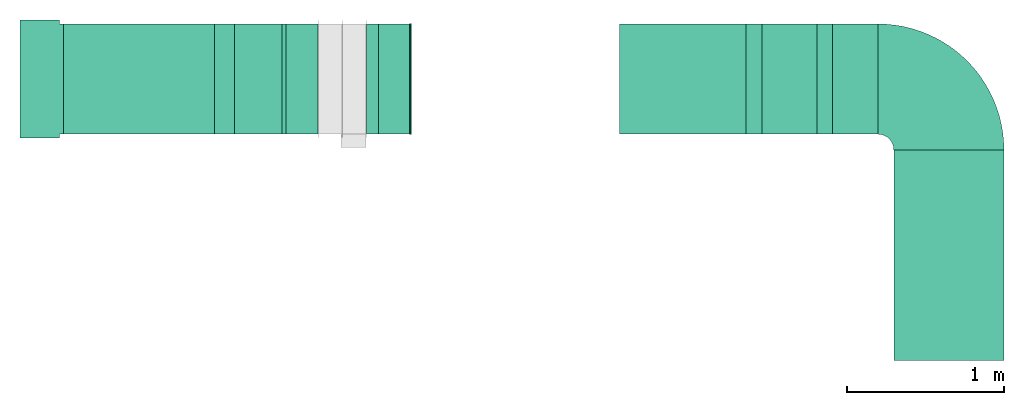
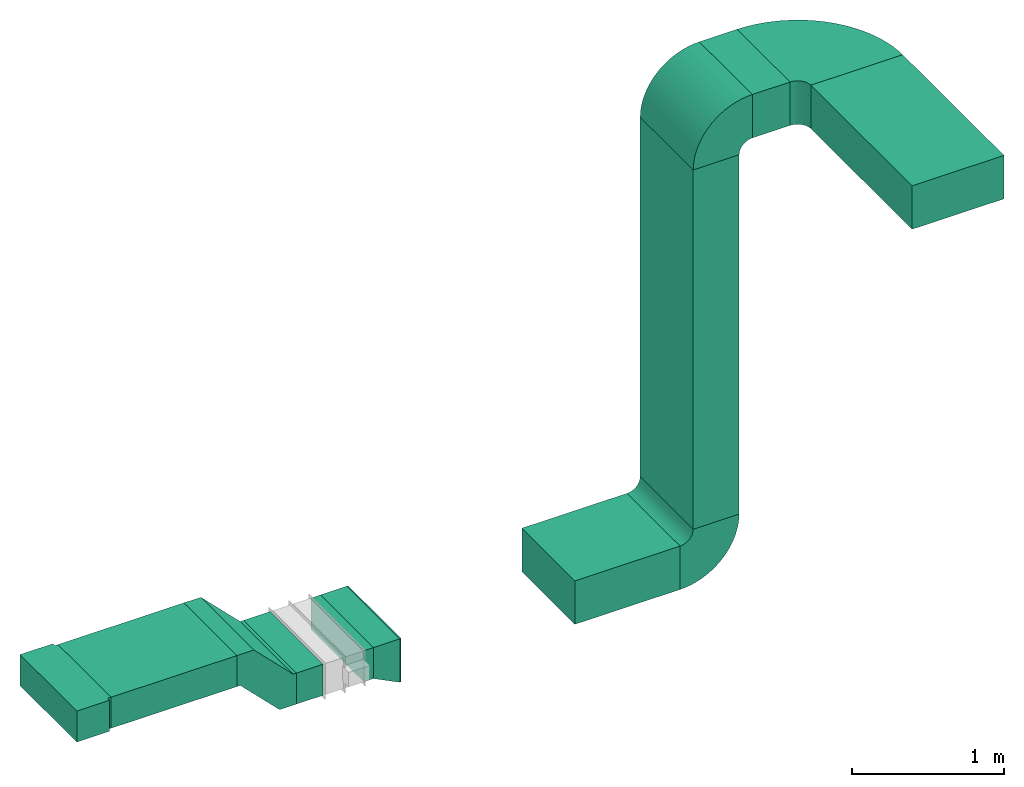
# One storey, part 1 of 2: 8 flow segments, 6 flow fittings.
"""IFC2X3 building model written with IfcOpenShell, lengths in millimetres."""

from ifc_helpers import new_model, entity, si_unit, converted_unit, derived_unit, direction, frame, frame_2d, origin, origin_2d_with_axis, place, context, subcontext, project, spatial, polyline, circle_curve, parameter, trimmed, segment, composite_curve, rectangle, outline, extrude, source, transform, mapped, material, type_object, type_shapes, element, save


model = new_model("IFC2X3")

# Units and contexts
model_context = context("Model", 3, precision=0.01, world=origin(), true_north=direction((6.12303176911189e-17, 1.0)))
body_context = subcontext(model_context, "Body", "Model", "MODEL_VIEW")
ifc_project = project(units=[si_unit("LENGTHUNIT", "METRE", prefix="MILLI"), si_unit("AREAUNIT", "SQUARE_METRE"), si_unit("VOLUMEUNIT", "CUBIC_METRE"), converted_unit("PLANEANGLEUNIT", "DEGREE", entity("IfcRatioMeasure", 0.0174532925199433), si_unit("PLANEANGLEUNIT", "RADIAN"), dimensions=[0, 0, 0, 0, 0, 0, 0]), si_unit("MASSUNIT", "GRAM", prefix="KILO"), derived_unit("MASSDENSITYUNIT", [(si_unit("MASSUNIT", "GRAM", prefix="KILO"), 1), (si_unit("LENGTHUNIT", "METRE"), -3)]), si_unit("TIMEUNIT", "SECOND"), si_unit("FREQUENCYUNIT", "HERTZ"), si_unit("THERMODYNAMICTEMPERATUREUNIT", "DEGREE_CELSIUS"), derived_unit("THERMALTRANSMITTANCEUNIT", [(si_unit("MASSUNIT", "GRAM", prefix="KILO"), 1), (si_unit("THERMODYNAMICTEMPERATUREUNIT", "KELVIN"), -1), (si_unit("TIMEUNIT", "SECOND"), -3)]), derived_unit("VOLUMETRICFLOWRATEUNIT", [(si_unit("LENGTHUNIT", "METRE"), 3), (si_unit("TIMEUNIT", "SECOND"), -1)]), si_unit("ELECTRICCURRENTUNIT", "AMPERE"), si_unit("ELECTRICVOLTAGEUNIT", "VOLT"), si_unit("POWERUNIT", "WATT"), si_unit("FORCEUNIT", "NEWTON", prefix="KILO"), si_unit("ILLUMINANCEUNIT", "LUX"), si_unit("LUMINOUSFLUXUNIT", "LUMEN"), si_unit("LUMINOUSINTENSITYUNIT", "CANDELA"), derived_unit("USERDEFINED", [(si_unit("MASSUNIT", "GRAM", prefix="KILO"), -1), (si_unit("LENGTHUNIT", "METRE"), -2), (si_unit("TIMEUNIT", "SECOND"), 3), (si_unit("LUMINOUSFLUXUNIT", "LUMEN"), 1)]), derived_unit("LINEARVELOCITYUNIT", [(si_unit("LENGTHUNIT", "METRE"), 1), (si_unit("TIMEUNIT", "SECOND"), -1)]), si_unit("PRESSUREUNIT", "PASCAL"), derived_unit("USERDEFINED", [(si_unit("LENGTHUNIT", "METRE"), -2), (si_unit("MASSUNIT", "GRAM", prefix="KILO"), 1), (si_unit("TIMEUNIT", "SECOND"), -2)])], contexts=[model_context])

# Site, building, storey
site_placement = place(None, origin())
site = spatial("IfcSite", under=ifc_project, at=site_placement, CompositionType="ELEMENT")
building_placement = place(site_placement, origin())
building = spatial("IfcBuilding", under=site, at=building_placement, CompositionType="ELEMENT")
storey_placement = place(building_placement, frame((0.0, 0.0, 16000.0)))
storey = spatial("IfcBuildingStorey", under=building, at=storey_placement, Name="04 Roof", CompositionType="ELEMENT", Elevation=16000.0)

# Flow segments
duct_segment_type = type_object("IfcDuctSegmentType", Name="Rectangular Duct:Air", PredefinedType="NOTDEFINED")
flow_segment_1_placement = place(storey_placement, frame((26073.4900708518, -69181.2395851399, 1110.95052634352)))
element("IfcFlowSegment", 1, at=flow_segment_1_placement, inside=storey, type_object=duct_segment_type, Name="Rectangular Duct:Air", ObjectType="Rectangular Duct:Air", context=body_context, shape_type="SweptSolid", body=[
    extrude(rectangle(XDim=958.820679167768, YDim=699.999999999997, at=frame_2d((0.0, 8.66862137627322e-12), x_axis=(1.0, 0.0))), frame((479.410339583884, 350.0, 0.0)), (0.0, 0.0, 1.0), 249.999999999999),
])
flow_segment_2_placement = place(storey_placement, frame((27999.4309510203, -69181.23958514, 810.950526343517)))
element("IfcFlowSegment", 2, at=flow_segment_2_placement, inside=storey, type_object=duct_segment_type, Name="Rectangular Duct:Air", ObjectType="Rectangular Duct:Air", context=body_context, shape_type="SweptSolid", body=[
    extrude(rectangle(XDim=73.9593931630735, YDim=699.999999999997, at=origin_2d_with_axis()), frame((36.9796965815368, 350.0, 0.0), z_axis=(0.0, 0.0, 1.0), x_axis=(-1.0, 0.0, 0.0)), (0.0, 0.0, 1.0), 249.999999999999),
])
flow_segment_3_placement = place(storey_placement, frame((28273.3903441834, -69181.2395851399, 710.950526343513)))
element("IfcFlowSegment", 3, at=flow_segment_3_placement, inside=storey, type_object=duct_segment_type, Name="Rectangular Duct:Air", ObjectType="Rectangular Duct:Air", context=body_context, shape_type="SweptSolid", body=[
    extrude(rectangle(XDim=10.1999048001152, YDim=699.999999999997, at=frame_2d((4.33164615287751e-12, 0.0), x_axis=(1.0, 0.0))), frame((5.09995240006192, 350.0, 0.0), z_axis=(0.0, 0.0, 1.0), x_axis=(-1.0, 0.0, 0.0)), (0.0, 0.0, 1.0), 349.999999999998),
])
flow_segment_4_placement = place(storey_placement, frame((29606.4616901155, -69181.2395851399, 710.950526343513)))
element("IfcFlowSegment", 4, at=flow_segment_4_placement, inside=storey, type_object=duct_segment_type, Name="Rectangular Duct:Air", ObjectType="Rectangular Duct:Air", context=body_context, shape_type="SweptSolid", body=[
    extrude(rectangle(XDim=802.028380736293, YDim=699.999999999997, at=frame_2d((4.34852154285181e-12, 8.66862137627322e-12), x_axis=(1.0, 0.0))), frame((401.014190368142, 350.0, 0.0)), (0.0, 0.0, 1.0), 349.999999999998),
])
flow_segment_5_placement = place(storey_placement, frame((30958.4900708518, -69181.23958514, 4155.0)))
element("IfcFlowSegment", 5, at=flow_segment_5_placement, inside=storey, type_object=duct_segment_type, Name="Rectangular Duct:Air", ObjectType="Rectangular Duct:Air", context=body_context, shape_type="SweptSolid", body=[
    extrude(rectangle(XDim=287.999492042562, YDim=699.999999999997, at=frame_2d((-2.17426077142591e-12, 8.66862137627322e-12), x_axis=(1.0, 0.0))), frame((143.999746021279, 350.0, 0.0), z_axis=(0.0, 0.0, 1.0), x_axis=(-1.0, 0.0, 0.0)), (0.0, 0.0, 1.0), 349.999999999998),
])
flow_segment_6_placement = place(storey_placement, frame((30508.4900708518, -69181.23958514, 1160.95052634351)))
element("IfcFlowSegment", 6, at=flow_segment_6_placement, inside=storey, type_object=duct_segment_type, Name="Rectangular Duct:Air", ObjectType="Rectangular Duct:Air", context=body_context, shape_type="SweptSolid", body=[
    extrude(rectangle(XDim=349.999999999998, YDim=699.999999999997, at=origin_2d_with_axis()), frame((175.0, 350.0, 0.0), z_axis=(0.0, 0.0, 1.0), x_axis=(-1.0, 0.0, 0.0)), (0.0, 0.0, 1.0), 2894.0494736565),
])
flow_segment_7_placement = place(storey_placement, frame((31346.4895628944, -70617.9433547428, 4155.0)))
element("IfcFlowSegment", 7, at=flow_segment_7_placement, inside=storey, type_object=duct_segment_type, Name="Rectangular Duct:Air", ObjectType="Rectangular Duct:Air", context=body_context, shape_type="SweptSolid", body=[
    extrude(rectangle(XDim=1336.70376960278, YDim=700.000000000001, at=frame_2d((-8.64019966684282e-12, 2.1600499167107e-12), x_axis=(1.0, 0.0))), frame((350.0, 668.351884801404, 0.0), z_axis=(0.0, 0.0, 1.0), x_axis=(0.0, 1.0, 0.0)), (0.0, 0.0, 1.0), 349.999999999998),
])
flow_segment_8_placement = place(storey_placement, frame((27486.6641406128, -69181.2395851399, 810.95052634352)))
element("IfcFlowSegment", 8, at=flow_segment_8_placement, inside=storey, type_object=duct_segment_type, Name="Rectangular Duct:Air", ObjectType="Rectangular Duct:Air", context=body_context, shape_type="SweptSolid", body=[
    extrude(rectangle(XDim=202.766810407452, YDim=699.999999999997, at=frame_2d((0.0, 8.66862137627322e-12), x_axis=(1.0, 0.0))), frame((101.383405203726, 350.0, 0.0)), (0.0, 0.0, 1.0), 249.999999999999),
])

# Flow fittings
duct_fitting_type_1 = type_object("IfcDuctFittingType", Name="Air_Rect", PredefinedType="NOTDEFINED")
shared_shape_1 = source(origin(), body_context, "Body", "SweptSolid", [
    extrude(outline(polyline([(-375.0, 56.2500000000001), (-375.0, -193.75), (375.0, -193.75), (375.0, 56.25), (350.0, 56.25), (350.0, 81.2499999999987), (-350.0, 81.2500000000011), (-350.0, 56.2500000000001), (-375.0, 56.2500000000001)])), frame((0.0, -68.75, -125.0), z_axis=(0.0, 0.0, -1.0), x_axis=(1.0, 0.0, 0.0)), (0.0, 0.0, -1.0), 250.0),
])
type_shapes(duct_fitting_type_1, [shared_shape_1])
flow_fitting_1_placement = place(storey_placement, frame((25923.4900708518, -68831.2395851399, 1235.95052634352), z_axis=(0.0, 0.0, 1.0), x_axis=(0.0, 1.0, 0.0)))
element("IfcFlowFitting", 9, at=flow_fitting_1_placement, inside=storey, type_object=duct_fitting_type_1, Name="1_001:Air_Rect", ObjectType="1_001:Air_Rect", context=body_context, shape_type="MappedRepresentation", body=[
    mapped(shared_shape_1, transform((0.0, 0.0, 0.0), scale=1.0)),
])
duct_fitting_type_2 = type_object("IfcDuctFittingType", Name="Standard", PredefinedType="NOTDEFINED")
shared_shape_2 = source(origin(), body_context, "Body", "SweptSolid", [
    extrude(outline(polyline([(-227.176695296637, -275.0), (-98.2233047033632, -275.0), (201.776695296637, 25.0), (227.176695296637, 25.0), (227.176695296637, 275.0), (98.2233047033631, 275.0), (-201.776695296637, -25.0), (-227.176695296637, -25.0), (-227.176695296637, -275.0)])), frame((227.176695296643, 150.0, -350.0)), (0.0, 0.0, 1.0), 700.0),
])
type_shapes(duct_fitting_type_2, [shared_shape_2])
flow_fitting_2_placement = place(storey_placement, frame((27032.3107500196, -68831.2395851399, 1235.9505263435), z_axis=(0.0, 1.0, 0.0), x_axis=(1.0, 0.0, 0.0)))
element("IfcFlowFitting", 10, at=flow_fitting_2_placement, inside=storey, type_object=duct_fitting_type_2, Name="M_Rectangular Offset - Plain - Flanged:Standard", ObjectType="M_Rectangular Offset - Plain - Flanged:Standard", context=body_context, shape_type="MappedRepresentation", body=[
    mapped(shared_shape_2, transform((0.0, 0.0, 0.0), scale=1.0)),
])
duct_fitting_type_3 = type_object("IfcDuctFittingType", Name="Air_Elbow_Rect", PredefinedType="NOTDEFINED")
shared_shape_3 = source(origin(), body_context, "Body", "SweptSolid", [
    extrude(outline(composite_curve([segment(polyline([(-312.5, -137.5), (37.5, -137.5)]), True, "CONTINUOUS"), segment(trimmed(circle_curve(frame_2d((137.5, -137.5), x_axis=(0.0, 1.0)), 100.0), [parameter(0.0)], [parameter(90.0000000000001)], True, "PARAMETER"), False, "CONTINUOUS"), segment(polyline([(137.5, -37.4999999999998), (137.5, 312.5)]), True, "CONTINUOUS"), segment(trimmed(circle_curve(frame_2d((137.5, -137.5), x_axis=(0.0, 1.0)), 450.0), [parameter(0.0)], [parameter(90.0000000000001)], True, "PARAMETER"), True, "CONTINUOUS")], self_intersect=False)), frame((-137.499999999999, 137.5, -350.0), z_axis=(0.0, 0.0, 1.0), x_axis=(-1.0, 0.0, 0.0)), (0.0, 0.0, 1.0), 700.0),
])
type_shapes(duct_fitting_type_3, [shared_shape_3])
for number, where, z_axis, x_axis, name in (
    (11, (30683.4900708518, -68831.2395851399, 885.950526343512), (0.0, -1.0, 0.0), (1.0, 0.0, 0.0), "elbow1_001:Air_Elbow_Rect"),
    (12, (30683.4900708518, -68831.23958514, 4330.0), (0.0, 1.0, 0.0), (0.0, 0.0, 1.0), "elbow1_001:Air_Elbow_Rect"),
):
    element("IfcFlowFitting", number, at=place(storey_placement, frame(where, z_axis=z_axis, x_axis=x_axis)), inside=storey, type_object=duct_fitting_type_3, Name=name, ObjectType="elbow1_001:Air_Elbow_Rect", context=body_context, shape_type="MappedRepresentation", body=[
        mapped(shared_shape_3, transform((0.0, 0.0, 0.0), scale=1.0)),
    ])
duct_fitting_type_4 = type_object("IfcDuctFittingType", Name="Air_Elbow_Rect", PredefinedType="NOTDEFINED")
shared_shape_4 = source(origin(), body_context, "Body", "SweptSolid", [
    extrude(outline(composite_curve([segment(polyline([(-575.0, -225.0), (125.0, -225.0)]), True, "CONTINUOUS"), segment(trimmed(circle_curve(frame_2d((225.0, -225.0), x_axis=(0.0, 1.0)), 100.0), [parameter(0.0)], [parameter(90.0000000000001)], True, "PARAMETER"), False, "CONTINUOUS"), segment(polyline([(225.0, -125.0), (225.0, 575.0)]), True, "CONTINUOUS"), segment(trimmed(circle_curve(frame_2d((225.0, -225.0), x_axis=(0.0, 1.0)), 800.0), [parameter(0.0)], [parameter(90.0)], True, "PARAMETER"), True, "CONTINUOUS")], self_intersect=False)), frame((-225.0, 225.0, -175.0), z_axis=(0.0, 0.0, 1.0), x_axis=(-1.0, 0.0, 0.0)), (0.0, 0.0, 1.0), 350.0),
])
type_shapes(duct_fitting_type_4, [shared_shape_4])
flow_fitting_3_placement = place(storey_placement, frame((31696.4895628944, -68831.23958514, 4330.0), z_axis=(0.0, 0.0, 1.0), x_axis=(0.0, 1.0, 0.0)))
element("IfcFlowFitting", 13, at=flow_fitting_3_placement, inside=storey, type_object=duct_fitting_type_4, Name="elbow1_001:Air_Elbow_Rect", ObjectType="elbow1_001:Air_Elbow_Rect", context=body_context, shape_type="MappedRepresentation", body=[
    mapped(shared_shape_4, transform((0.0, 0.0, 0.0), scale=1.0)),
])
ifc_material = material(Name="DF_Material1")
duct_fitting_type_5 = type_object("IfcDuctFittingType", Name="Air_LRD", PredefinedType="NOTDEFINED", material=ifc_material)
shared_shape_5 = source(origin(), body_context, "Body", "SweptSolid", [
    extrude(rectangle(XDim=1.99999999999999, YDim=700.0, at=origin_2d_with_axis()), frame((199.0, 0.0, -75.0), z_axis=(0.0, 0.0, 1.0), x_axis=(-1.0, 0.0, 0.0)), (0.0, 0.0, 1.0), 250.0),
    extrude(rectangle(XDim=2.0, YDim=700.0, at=origin_2d_with_axis()), frame((1.0, 0.0, -175.0), z_axis=(0.0, 0.0, 1.0), x_axis=(-1.0, 0.0, 0.0)), (0.0, 0.0, 1.0), 350.0),
    extrude(outline(polyline([(-100.0, -150.0), (100.0, -150.0), (100.0, 100.0), (-100.0, 200.0), (-100.0, -150.0)])), frame((100.0, -350.0, 25.0), z_axis=(0.0, 1.0, 0.0), x_axis=(1.0, 0.0, 0.0)), (0.0, 0.0, 1.0), 700.0),
])
type_shapes(duct_fitting_type_5, [shared_shape_5])
flow_fitting_4_placement = place(storey_placement, frame((28273.3903441834, -68831.23958514, 885.950526343512), z_axis=(0.0, 0.0, 1.0), x_axis=(-1.0, 0.0, 0.0)))
element("IfcFlowFitting", 14, at=flow_fitting_4_placement, inside=storey, type_object=duct_fitting_type_5, material=ifc_material, Name="LDR:Air", ObjectType="LDR:Air_LRD", context=body_context, shape_type="MappedRepresentation", body=[
    mapped(shared_shape_5, transform((0.0, 0.0, 0.0), scale=1.0)),
])

save(model, "model.ifc")
